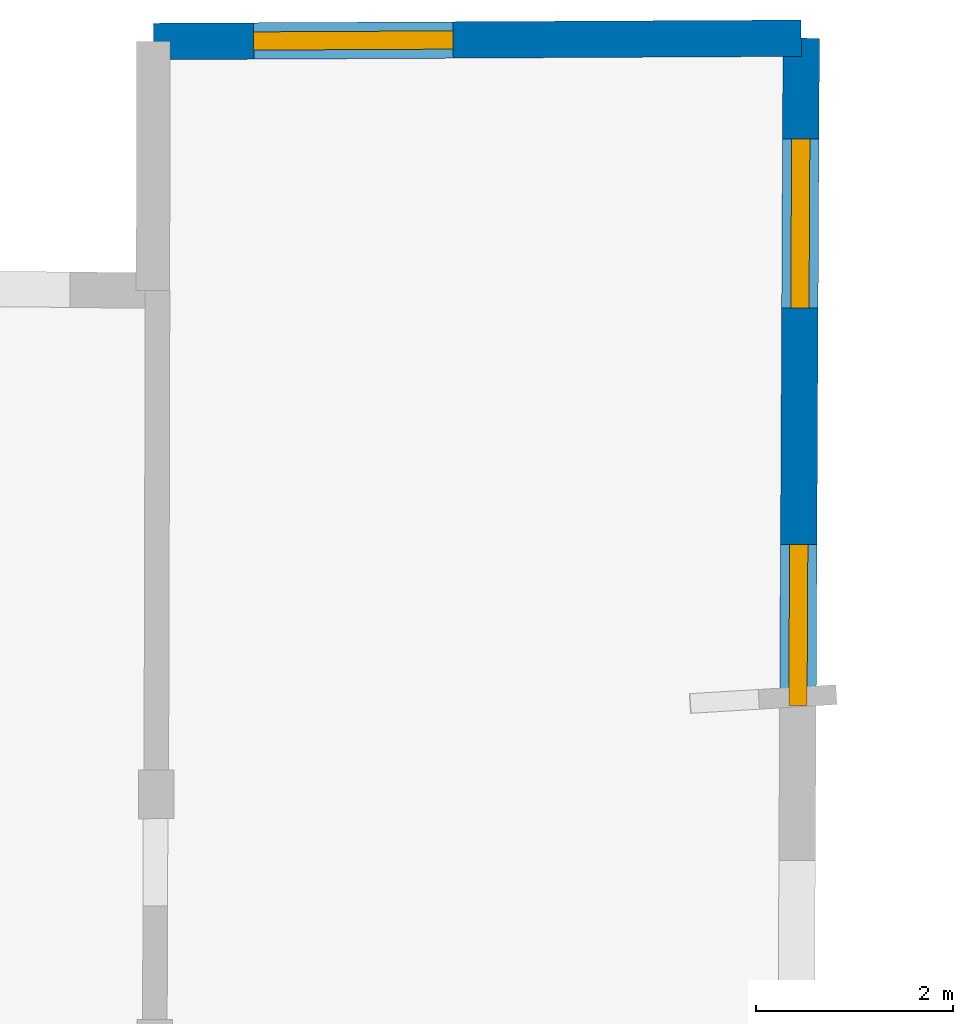
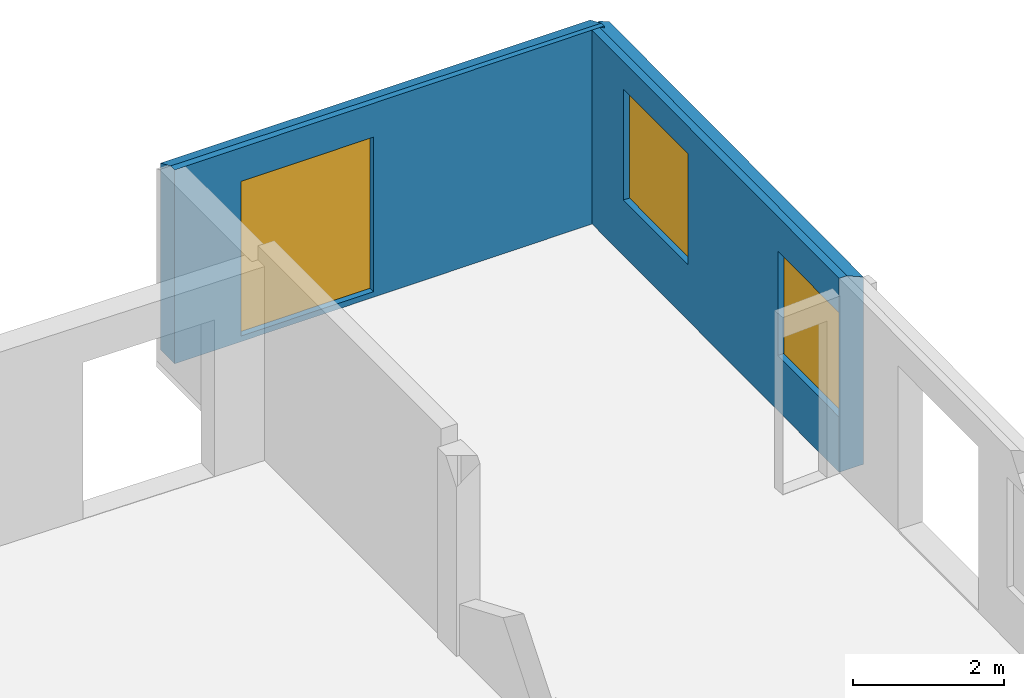
# One storey, part 9 of 10: 3 windows, 2 walls, 3 openings.
"""IFC2X3 building model written with IfcOpenShell, lengths in metres."""

from ifc_helpers import new_model, entity, si_unit, converted_unit, derived_unit, direction, frame, frame_2d, origin, origin_2d_with_axis, place, context, subcontext, project, spatial, polyline, rectangle, outline, extrude, clip, halfspace, source, transform, mapped, material, layer, layer_set, layer_usage, type_object, type_shapes, element, fill, save


model = new_model("IFC2X3")

# Units and contexts
model_context = context("Model", 3, precision=1e-05, world=origin(), true_north=direction((0.0, 1.0)))
body_context = subcontext(model_context, "Body", "Model", "MODEL_VIEW")
ifc_project = project(units=[si_unit("LENGTHUNIT", "METRE"), si_unit("AREAUNIT", "SQUARE_METRE"), si_unit("VOLUMEUNIT", "CUBIC_METRE"), converted_unit("PLANEANGLEUNIT", "DEGREE", entity("IfcRatioMeasure", 0.0174532925199433), si_unit("PLANEANGLEUNIT", "RADIAN"), dimensions=[0, 0, 0, 0, 0, 0, 0]), si_unit("MASSUNIT", "GRAM", prefix="KILO"), derived_unit("MASSDENSITYUNIT", [(si_unit("MASSUNIT", "GRAM", prefix="KILO"), 1), (si_unit("LENGTHUNIT", "METRE"), -3)]), derived_unit("MOMENTOFINERTIAUNIT", [(si_unit("LENGTHUNIT", "METRE"), 4)]), si_unit("TIMEUNIT", "SECOND"), si_unit("FREQUENCYUNIT", "HERTZ"), si_unit("THERMODYNAMICTEMPERATUREUNIT", "DEGREE_CELSIUS"), derived_unit("THERMALTRANSMITTANCEUNIT", [(si_unit("MASSUNIT", "GRAM", prefix="KILO"), 1), (si_unit("THERMODYNAMICTEMPERATUREUNIT", "KELVIN"), -1), (si_unit("TIMEUNIT", "SECOND"), -3)]), derived_unit("VOLUMETRICFLOWRATEUNIT", [(si_unit("LENGTHUNIT", "METRE"), 3), (si_unit("TIMEUNIT", "SECOND"), -1)]), si_unit("ELECTRICCURRENTUNIT", "AMPERE"), si_unit("ELECTRICVOLTAGEUNIT", "VOLT"), si_unit("POWERUNIT", "WATT"), si_unit("FORCEUNIT", "NEWTON", prefix="KILO"), si_unit("ILLUMINANCEUNIT", "LUX"), si_unit("LUMINOUSFLUXUNIT", "LUMEN"), si_unit("LUMINOUSINTENSITYUNIT", "CANDELA"), derived_unit("USERDEFINED", [(si_unit("MASSUNIT", "GRAM", prefix="KILO"), -1), (si_unit("LENGTHUNIT", "METRE"), -2), (si_unit("TIMEUNIT", "SECOND"), 3), (si_unit("LUMINOUSFLUXUNIT", "LUMEN"), 1)]), derived_unit("LINEARVELOCITYUNIT", [(si_unit("LENGTHUNIT", "METRE"), 1), (si_unit("TIMEUNIT", "SECOND"), -1)]), si_unit("PRESSUREUNIT", "PASCAL"), derived_unit("USERDEFINED", [(si_unit("LENGTHUNIT", "METRE"), -2), (si_unit("MASSUNIT", "GRAM", prefix="KILO"), 1), (si_unit("TIMEUNIT", "SECOND"), -2)]), derived_unit("LINEARFORCEUNIT", [(si_unit("MASSUNIT", "GRAM", prefix="KILO"), 1), (si_unit("LENGTHUNIT", "METRE"), 1), (si_unit("TIMEUNIT", "SECOND"), -2), (si_unit("LENGTHUNIT", "METRE"), -1)]), derived_unit("PLANARFORCEUNIT", [(si_unit("MASSUNIT", "GRAM", prefix="KILO"), 1), (si_unit("LENGTHUNIT", "METRE"), 1), (si_unit("TIMEUNIT", "SECOND"), -2), (si_unit("LENGTHUNIT", "METRE"), -2)])], contexts=[model_context])

# Site, building, storey
placement = place(None, origin())
site = spatial("IfcSite", under=ifc_project, at=placement, CompositionType="ELEMENT")
building = spatial("IfcBuilding", under=site, at=placement, CompositionType="ELEMENT")
storey_placement = place(placement, frame((0.0, 0.0, 15.2695512771606)))
storey = spatial("IfcBuildingStorey", under=building, at=storey_placement, Name="Level 6", CompositionType="ELEMENT", Elevation=15.2695512771606)

# Wall, openings, windows
ifc_material_1 = material(Name="Default wall")
ifc_layer = layer(ifc_material_1, 0.370000004768372)
ifc_layer_set = layer_set([ifc_layer], Name="wall_thickness_0.3700")
ifc_layer_usage = layer_usage(ifc_layer_set, "AXIS2", "POSITIVE", -0.185000002384186)
wall_type = type_object("IfcWallType", Name="wall_thickness_0.3700", PredefinedType="STANDARD", material=ifc_layer_set)
wall_1_placement = place(storey_placement, frame((12.9701794049302, 77.3544057785226, 0.0), z_axis=(0.0, 0.0, 1.0), x_axis=(-0.00497673144290278, -0.999987615995391, 0.0)))
wall_1 = element("IfcWallStandardCase", 1, at=wall_1_placement, inside=storey, type_object=wall_type, material=ifc_layer_usage, Name="Wall:198", ObjectType="Wall", context=body_context, shape_type="Clipping", body=[
    clip(clip(extrude(outline(polyline([(6.77572630564533, -0.185000002384186), (6.77572630564533, 0.185000002384186), (0.0, 0.185000002384186), (0.0, -0.185000002384186), (6.77572630564533, -0.185000002384186)])), origin(), (0.0, 0.0, 1.0), 3.13044834136963), halfspace(frame((-1.16721548177036, 0.619409667677467, 2.58209439152611), z_axis=(-0.395632162300277, -0.00212392838072588, 0.918406598997329), x_axis=(0.00536836845704091, -0.999985590206234, 0.0)), False)), halfspace(frame((0.118550977015307, -0.153066798519967, 3.16730048752112), z_axis=(-3.96158968369415e-05, 0.390500120725587, 0.920602875372374), x_axis=(0.673652222792163, -0.680359692540974, 0.288623234499112)), False)),
])
opening_1_placement = place(wall_1_placement, frame((1.02389266451076, -0.185000002384186, 0.897448539733887)))
opening_1 = element("IfcOpeningElement", 2, at=opening_1_placement, cuts=wall_1, Name="Opening : 1715 x 1790 : 176", ObjectType="Opening", context=body_context, shape_type="SweptSolid", body=[
    extrude(rectangle(XDim=1.715, YDim=1.79, at=frame_2d((0.895, 0.8575), x_axis=(0.0, 1.0))), frame((0.0, 0.0, 0.0), z_axis=(0.0, 1.0, 0.0), x_axis=(0.0, 0.0, 1.0)), (0.0, 0.0, 1.0), 0.370000004768372),
])
opening_2_placement = place(wall_1_placement, frame((5.13897963411789, -0.185000002384186, 0.890448570251465)))
opening_2 = element("IfcOpeningElement", 3, at=opening_2_placement, cuts=wall_1, Name="Opening : 1635 x 1685 : 177", ObjectType="Opening", context=body_context, shape_type="SweptSolid", body=[
    extrude(rectangle(XDim=1.635, YDim=1.685, at=frame_2d((0.8425, 0.8175), x_axis=(0.0, 1.0))), frame((0.0, 0.0, 0.0), z_axis=(0.0, 1.0, 0.0), x_axis=(0.0, 0.0, 1.0)), (0.0, 0.0, 1.0), 0.370000004768372),
])
ifc_material_2 = material(Name="Window Default")
window_style_1 = type_object("IfcWindowStyle", Name="Window : 1715 x 1790mm", ConstructionType="NOTDEFINED", OperationType="NOTDEFINED", ParameterTakesPrecedence=False, Sizeable=False, material=ifc_material_2)
shared_shape_1 = source(origin(), body_context, "Body", "SweptSolid", [
    extrude(rectangle(XDim=0.185000002384186, YDim=1.715, at=origin_2d_with_axis()), frame((0.8575, 0.185000002384186, 0.0), z_axis=(0.0, 0.0, 1.0), x_axis=(0.0, 1.0, 0.0)), (0.0, 0.0, 1.0), 1.79),
])
type_shapes(window_style_1, [shared_shape_1])
window_1_placement = place(opening_1_placement, origin())
window_1 = element("IfcWindow", 4, at=window_1_placement, inside=storey, type_object=window_style_1, Name="Window : 1715 x 1790mm : 96", ObjectType="Window : 1715 x 1790mm", OverallHeight=1.79, OverallWidth=1.715, context=body_context, shape_type="MappedRepresentation", body=[
    mapped(shared_shape_1, transform((0.0, 0.0, 0.0), scale=1.0)),
])
fill(opening_1, window_1)
window_style_2 = type_object("IfcWindowStyle", Name="Window : 1635 x 1685mm", ConstructionType="NOTDEFINED", OperationType="NOTDEFINED", ParameterTakesPrecedence=False, Sizeable=False, material=ifc_material_2)
shared_shape_2 = source(origin(), body_context, "Body", "SweptSolid", [
    extrude(rectangle(XDim=0.185000002384186, YDim=1.635, at=origin_2d_with_axis()), frame((0.8175, 0.185000002384186, 0.0), z_axis=(0.0, 0.0, 1.0), x_axis=(0.0, 1.0, 0.0)), (0.0, 0.0, 1.0), 1.685),
])
type_shapes(window_style_2, [shared_shape_2])
window_2_placement = place(opening_2_placement, origin())
window_2 = element("IfcWindow", 5, at=window_2_placement, inside=storey, type_object=window_style_2, Name="Window : 1635 x 1685mm : 97", ObjectType="Window : 1635 x 1685mm", OverallHeight=1.685, OverallWidth=1.635, context=body_context, shape_type="MappedRepresentation", body=[
    mapped(shared_shape_2, transform((0.0, 0.0, 0.0), scale=1.0)),
])
fill(opening_2, window_2)

# Wall, opening, window
wall_2_placement = place(storey_placement, frame((6.39242913907583, 77.3210829992235, 0.0), z_axis=(0.0, 0.0, 1.0), x_axis=(0.999987166280326, 0.00506628805379342, 0.0)))
wall_2 = element("IfcWallStandardCase", 6, at=wall_2_placement, inside=storey, type_object=wall_type, material=ifc_layer_usage, Name="Wall:226", ObjectType="Wall", context=body_context, shape_type="Clipping", body=[
    clip(extrude(outline(polyline([(6.57783271670617, -0.185000002384186), (6.57783271670617, 0.185000002384186), (0.0, 0.185000002384186), (0.0, -0.185000002384186), (6.57783271670617, -0.185000002384186)])), origin(), (0.0, 0.0, 1.0), 3.13044834136963), halfspace(frame((7.208935321862, 1.16093352689205, 2.58209439152611), z_axis=(0.00184947015951536, 0.395633540512288, 0.918406598997329), x_axis=(-0.999989073761915, 0.00467465044556523, 0.0)), False)),
])
opening_3_placement = place(wall_2_placement, frame((1.01900167531201, -0.185000002384186, 0.090449333190918)))
opening_3 = element("IfcOpeningElement", 7, at=opening_3_placement, cuts=wall_2, Name="Opening : 2025 x 2495 : 202", ObjectType="Opening", context=body_context, shape_type="SweptSolid", body=[
    extrude(rectangle(XDim=2.025, YDim=2.495, at=frame_2d((1.2475, 1.0125), x_axis=(0.0, 1.0))), frame((0.0, 0.0, 0.0), z_axis=(0.0, 1.0, 0.0), x_axis=(0.0, 0.0, 1.0)), (0.0, 0.0, 1.0), 0.370000004768372),
])
window_style_3 = type_object("IfcWindowStyle", Name="Window : 2025 x 2495mm", ConstructionType="NOTDEFINED", OperationType="NOTDEFINED", ParameterTakesPrecedence=False, Sizeable=False, material=ifc_material_2)
shared_shape_3 = source(origin(), body_context, "Body", "SweptSolid", [
    extrude(rectangle(XDim=0.185000002384186, YDim=2.025, at=origin_2d_with_axis()), frame((1.0125, 0.185000002384186, 0.0), z_axis=(0.0, 0.0, 1.0), x_axis=(0.0, 1.0, 0.0)), (0.0, 0.0, 1.0), 2.495),
])
type_shapes(window_style_3, [shared_shape_3])
window_3_placement = place(opening_3_placement, origin())
window_3 = element("IfcWindow", 8, at=window_3_placement, inside=storey, type_object=window_style_3, Name="Window : 2025 x 2495mm : 108", ObjectType="Window : 2025 x 2495mm", OverallHeight=2.495, OverallWidth=2.025, context=body_context, shape_type="MappedRepresentation", body=[
    mapped(shared_shape_3, transform((0.0, 0.0, 0.0), scale=1.0)),
])
fill(opening_3, window_3)

save(model, "model.ifc")
